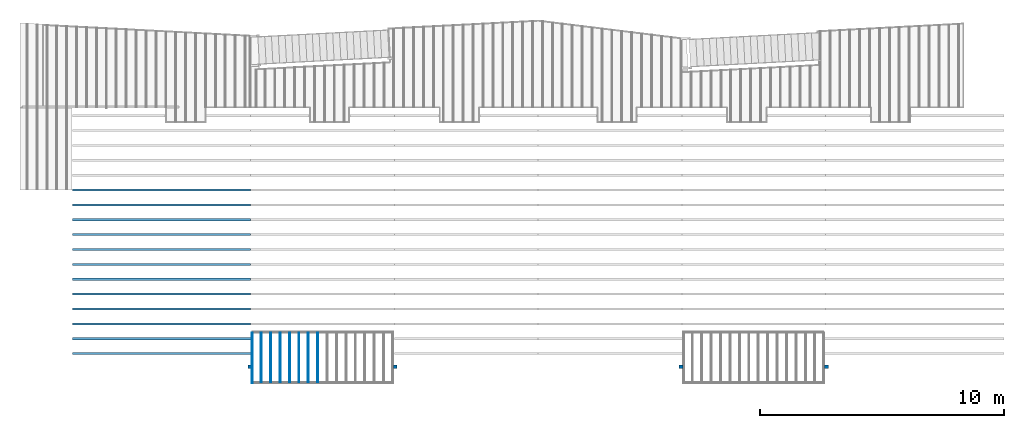
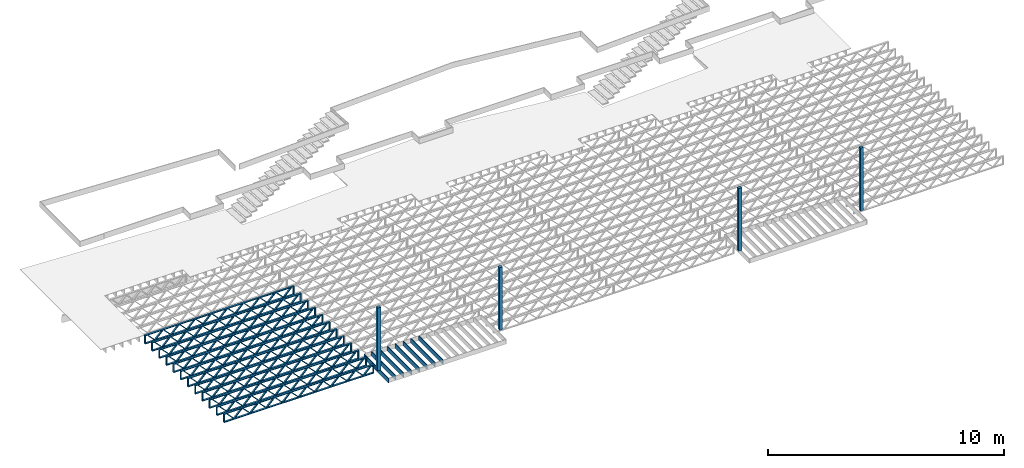
# One storey, part 1 of 23: 20 beams, 4 columns, 2 elements without a shape of their own.
"""IFC4 building model written with IfcOpenShell, lengths in feet."""

import ifcopenshell
import ifcopenshell.guid

model = None  # the IFC model being written
_history = None  # IfcOwnerHistory: only IFC2X3 demands one
_inside = {}  # id of a spatial element -> (the spatial element, [elements in it])
_under = {}  # id of a project, library or spatial element -> (it, [spatial elements below it])
_declared = {}  # id of a project -> (the project, [libraries it declares])
_typed = {}  # id of a type object -> (the type object, [elements of that type])
_made_of = {}  # id of a material, layer set ... -> (it, [elements and type objects made of it])


def new_model(schema):
    """Start an empty IFC model of exactly this schema.

    Asked for "IFC4X3", IfcOpenShell would pick the latest addendum, in which some entities
    have other attributes; the version numbers below select the first issue.
    IFC2X3 requires an IfcOwnerHistory on every rooted entity: one is made here for all.
    """
    global model, _history
    if schema == "IFC4X3":
        model = ifcopenshell.file(schema_version=(4, 3, 0, 0))
    else:
        model = ifcopenshell.file(schema=schema)
    _inside.clear()
    _under.clear()
    _declared.clear()
    _typed.clear()
    _made_of.clear()
    _history = None
    if model.schema == "IFC2X3":
        org = make("IfcOrganization", Name="unknown")
        user = make(
            "IfcPersonAndOrganization",
            ThePerson=make("IfcPerson", FamilyName="unknown"),
            TheOrganization=org,
        )
        app = make(
            "IfcApplication",
            ApplicationDeveloper=org,
            Version="unknown",
            ApplicationFullName="unknown",
            ApplicationIdentifier="unknown",
        )
        _history = make(
            "IfcOwnerHistory",
            OwningUser=user,
            OwningApplication=app,
            ChangeAction="ADDED",
            CreationDate=0,
        )
    return model


def make(cls, **values):
    """One entity of the class cls with the attributes given. An attribute that is None is left unset."""
    return model.create_entity(
        cls, **{name: value for name, value in values.items() if value is not None}
    )


def entity(cls, *values):
    """Any entity or typed value of the class cls, its attributes in the order of the schema. None: left unset."""
    e = model.create_entity(cls)
    for i, value in enumerate(values):
        if value is not None:
            e[i] = value
    return e


def rooted(cls, **values):
    """An entity with a GlobalId (a new one), such as an element, a storey or a relation."""
    return make(cls, GlobalId=ifcopenshell.guid.new(), OwnerHistory=_history, **values)


def si_unit(unit_type, name, prefix=None):
    """IfcSIUnit, for example si_unit("LENGTHUNIT", "METRE", prefix="MILLI")."""
    return make("IfcSIUnit", UnitType=unit_type, Prefix=prefix, Name=name)


def converted_unit(unit_type, name, factor, base, dimensions=None, offset=None):
    """IfcConversionBasedUnit, such as the inch: factor (a typed value) times the base unit."""
    return make(
        "IfcConversionBasedUnit"
        if offset is None
        else "IfcConversionBasedUnitWithOffset",
        ConversionOffset=offset,
        Dimensions=None
        if dimensions is None
        else entity("IfcDimensionalExponents", *dimensions),
        UnitType=unit_type,
        Name=name,
        ConversionFactor=make(
            "IfcMeasureWithUnit", ValueComponent=factor, UnitComponent=base
        ),
    )


def derived_unit(unit_type, elements):
    """IfcDerivedUnit: a product of units, each with its exponent."""
    return make(
        "IfcDerivedUnit",
        Elements=[
            make("IfcDerivedUnitElement", Unit=unit, Exponent=power)
            for unit, power in elements
        ],
        UnitType=unit_type,
    )


def assignment(units):
    """IfcUnitAssignment: the units of a project."""
    return None if units is None else make("IfcUnitAssignment", Units=units)


def point(xyz):
    """IfcCartesianPoint."""
    return None if xyz is None else make("IfcCartesianPoint", Coordinates=xyz)


def direction(xyz):
    """IfcDirection."""
    return None if xyz is None else make("IfcDirection", DirectionRatios=xyz)


def frame(location, z_axis=None, x_axis=None):
    """IfcAxis2Placement3D, a coordinate frame: its origin and axes. An axis left out is left unset."""
    return make(
        "IfcAxis2Placement3D",
        Location=point(location),
        Axis=direction(z_axis),
        RefDirection=direction(x_axis),
    )


def frame_2d(location, x_axis=None):
    """IfcAxis2Placement2D, a coordinate frame in the plane: its origin and x axis."""
    return make(
        "IfcAxis2Placement2D", Location=point(location), RefDirection=direction(x_axis)
    )


def origin():
    """The frame at (0, 0, 0) with its axes left unset."""
    return frame((0.0, 0.0, 0.0))


def origin_2d_with_axis():
    """The frame at (0, 0) in the plane with the x axis (1, 0) written out."""
    return frame_2d((0.0, 0.0), x_axis=(1.0, 0.0))


def place(relative_to, where):
    """IfcLocalPlacement: puts the frame where relative to a parent placement (None: the world)."""
    return make(
        "IfcLocalPlacement", PlacementRelTo=relative_to, RelativePlacement=where
    )


def context(
    kind, dimensions, precision=None, world=None, true_north=None, identifier=None
):
    """IfcGeometricRepresentationContext, for example the 3D "Model" context."""
    return make(
        "IfcGeometricRepresentationContext",
        ContextIdentifier=identifier,
        ContextType=kind,
        CoordinateSpaceDimension=dimensions,
        Precision=precision,
        WorldCoordinateSystem=world,
        TrueNorth=true_north,
    )


def subcontext(parent, identifier, kind, view, scale=None):
    """IfcGeometricRepresentationSubContext, for example "Body" below "Model"."""
    return make(
        "IfcGeometricRepresentationSubContext",
        ContextIdentifier=identifier,
        ContextType=kind,
        ParentContext=parent,
        TargetScale=scale,
        TargetView=view,
    )


def project(units=None, contexts=None):
    """IfcProject with its units and contexts."""
    return rooted(
        "IfcProject",
        Name="project",
        RepresentationContexts=contexts,
        UnitsInContext=assignment(units),
    )


def spatial(cls, under=None, at=None, **own):
    """A site, building, storey or space (cls), placed at a placement, below another one or the project."""
    s = rooted(cls, ObjectPlacement=at, **own)
    if under is not None:
        _under.setdefault(under.id(), (under, []))[1].append(s)
    return s


def profile(cls, at=None, kind="AREA", **sizes):
    """A parametric profile (cls). Its sizes go by their IFC names, for example OverallWidth=200.0."""
    return make(cls, ProfileType=kind, Position=at, **sizes)


def rectangle(**sizes):
    """IfcRectangleProfileDef."""
    return profile("IfcRectangleProfileDef", **sizes)


def extrude(swept, where, along, depth):
    """IfcExtrudedAreaSolid: the profile swept, set in the frame where, extruded along a direction by depth."""
    return make(
        "IfcExtrudedAreaSolid",
        SweptArea=swept,
        Position=where,
        ExtrudedDirection=direction(along),
        Depth=depth,
    )


def shape(context_of_items, identifier, shape_type, items):
    """IfcShapeRepresentation: the items that make up one representation, for example the "Body"."""
    return make(
        "IfcShapeRepresentation",
        ContextOfItems=context_of_items,
        RepresentationIdentifier=identifier,
        RepresentationType=shape_type,
        Items=items,
    )


def source(mapping_origin, context_of_items, identifier, shape_type, items):
    """IfcRepresentationMap: a shape defined once, which mapped items show again and again."""
    return make(
        "IfcRepresentationMap",
        MappingOrigin=mapping_origin,
        MappedRepresentation=shape(context_of_items, identifier, shape_type, items),
    )


def transform(
    local_origin,
    x_axis=None,
    y_axis=None,
    z_axis=None,
    scale=None,
    scale2=None,
    scale3=None,
    uniform=True,
):
    """IfcCartesianTransformationOperator3D, or its non-uniform kind. x_axis, y_axis, z_axis: its Axis1, 2, 3."""
    if uniform:
        return make(
            "IfcCartesianTransformationOperator3D",
            Axis1=direction(x_axis),
            Axis2=direction(y_axis),
            LocalOrigin=point(local_origin),
            Scale=scale,
            Axis3=direction(z_axis),
        )
    return make(
        "IfcCartesianTransformationOperator3DnonUniform",
        Axis1=direction(x_axis),
        Axis2=direction(y_axis),
        LocalOrigin=point(local_origin),
        Scale=scale,
        Axis3=direction(z_axis),
        Scale2=scale2,
        Scale3=scale3,
    )


def mapped(mapping_source, mapping_target):
    """IfcMappedItem: shows the shape of a source again, moved by a transform."""
    return make(
        "IfcMappedItem", MappingSource=mapping_source, MappingTarget=mapping_target
    )


def material(Name=None, Category=None):
    """IfcMaterial."""
    return make("IfcMaterial", Name=Name, Category=Category)


def material_profile(
    of_material, cross_section, Name=None, Category=None, Priority=None
):
    """IfcMaterialProfile: a cross section and its material."""
    return make(
        "IfcMaterialProfile",
        Name=Name,
        Material=of_material,
        Profile=cross_section,
        Priority=Priority,
        Category=Category,
    )


def profile_set(profiles, Name=None, composite=None):
    """IfcMaterialProfileSet."""
    return make(
        "IfcMaterialProfileSet",
        Name=Name,
        MaterialProfiles=profiles,
        CompositeProfile=composite,
    )


def profile_usage(for_profile_set, cardinal=None, extent=None):
    """IfcMaterialProfileSetUsage: how a profile set lies along its element."""
    return make(
        "IfcMaterialProfileSetUsage",
        ForProfileSet=for_profile_set,
        CardinalPoint=cardinal,
        ReferenceExtent=extent,
    )


def made_of(thing, what):
    """Note that an element or type object is made of a material, layer set ...; save() writes the relation."""
    if what is not None:
        _made_of.setdefault(what.id(), (what, []))[1].append(thing)
    return thing


def type_object(cls, material=None, **own):
    """A type object (cls), such as IfcWallType, which elements share."""
    return made_of(rooted(cls, **own), material)


def type_shapes(of_type, sources):
    """Give a type object the sources (RepresentationMaps) that its elements show as mapped items."""
    of_type.RepresentationMaps = sources


def element(
    cls,
    number,
    at=None,
    inside=None,
    cuts=None,
    type_object=None,
    material=None,
    context=None,
    identifier="Body",
    shape_type=None,
    held_by="IfcProductDefinitionShape",
    body=None,
    shapes=None,
    **own,
):
    """One element of the class cls, such as IfcWall. Its Tag is "e" and its number.

    at: its placement. inside: the storey or other place that contains it. cuts: it is an
    opening in that element (IfcRelVoidsElement). A single representation is given by context,
    identifier, shape_type and body (its items); several are given by shapes. held_by: the class
    of the entity that holds the representations. save() writes the other relations.
    """
    e = rooted(cls, Tag="e%d" % number, ObjectPlacement=at, **own)
    if body is not None:
        shapes = [shape(context, identifier, shape_type, body)]
    if shapes is not None:
        e.Representation = make(held_by, Representations=shapes)
    if inside is not None:
        _inside.setdefault(inside.id(), (inside, []))[1].append(e)
    if cuts is not None:
        rooted(
            "IfcRelVoidsElement", RelatingBuildingElement=cuts, RelatedOpeningElement=e
        )
    if type_object is not None:
        _typed.setdefault(type_object.id(), (type_object, []))[1].append(e)
    return made_of(e, material)


def aggregate(whole, parts):
    """IfcRelAggregates: a whole, such as a stair, and the parts it consists of."""
    return rooted("IfcRelAggregates", RelatingObject=whole, RelatedObjects=parts)


def save(model, path):
    """Write the relations noted so far, then the file.

    IfcRelAggregates (storeys below a building ...), IfcRelContainedInSpatialStructure (elements
    in a storey), IfcRelDefinesByType, IfcRelAssociatesMaterial and IfcRelDeclares: one each for
    every whole, place, type object, material and project.
    """
    for whole, parts in _under.values():
        aggregate(whole, parts)
    for where, things in _inside.values():
        rooted(
            "IfcRelContainedInSpatialStructure",
            RelatedElements=things,
            RelatingStructure=where,
        )
    for kind, things in _typed.values():
        rooted("IfcRelDefinesByType", RelatedObjects=things, RelatingType=kind)
    for what, things in _made_of.values():
        rooted("IfcRelAssociatesMaterial", RelatedObjects=things, RelatingMaterial=what)
    for by, libraries in _declared.values():
        rooted("IfcRelDeclares", RelatingContext=by, RelatedDefinitions=libraries)
    model.write(path)


model = new_model("IFC4")

# Units and contexts
model_context = context("Model", 3, precision=0.0001, world=origin(), true_north=direction((6.12303176911189e-17, 1.0)))
body_context = subcontext(model_context, "Body", "Model", "MODEL_VIEW")
ifc_project = project(units=[converted_unit("LENGTHUNIT", "FOOT", entity("IfcRatioMeasure", 0.3048), si_unit("LENGTHUNIT", "METRE"), dimensions=[1, 0, 0, 0, 0, 0, 0]), converted_unit("AREAUNIT", "SQUARE FOOT", entity("IfcRatioMeasure", 0.09290304), si_unit("AREAUNIT", "SQUARE_METRE"), dimensions=[2, 0, 0, 0, 0, 0, 0]), converted_unit("VOLUMEUNIT", "CUBIC FOOT", entity("IfcRatioMeasure", 0.028316846592), si_unit("VOLUMEUNIT", "CUBIC_METRE"), dimensions=[3, 0, 0, 0, 0, 0, 0]), converted_unit("PLANEANGLEUNIT", "DEGREE", entity("IfcRatioMeasure", 0.0174532925199433), si_unit("PLANEANGLEUNIT", "RADIAN"), dimensions=[0, 0, 0, 0, 0, 0, 0]), si_unit("MASSUNIT", "GRAM", prefix="KILO"), derived_unit("MASSDENSITYUNIT", [(si_unit("MASSUNIT", "GRAM", prefix="KILO"), 1), (si_unit("LENGTHUNIT", "METRE"), -3)]), derived_unit("MOMENTOFINERTIAUNIT", [(si_unit("LENGTHUNIT", "METRE"), 4)]), si_unit("TIMEUNIT", "SECOND"), si_unit("FREQUENCYUNIT", "HERTZ"), si_unit("THERMODYNAMICTEMPERATUREUNIT", "DEGREE_CELSIUS"), derived_unit("THERMALTRANSMITTANCEUNIT", [(si_unit("MASSUNIT", "GRAM", prefix="KILO"), 1), (si_unit("THERMODYNAMICTEMPERATUREUNIT", "KELVIN"), -1), (si_unit("TIMEUNIT", "SECOND"), -3)]), derived_unit("VOLUMETRICFLOWRATEUNIT", [(si_unit("LENGTHUNIT", "METRE"), 3), (si_unit("TIMEUNIT", "SECOND"), -1)]), si_unit("ELECTRICCURRENTUNIT", "AMPERE"), si_unit("ELECTRICVOLTAGEUNIT", "VOLT"), si_unit("POWERUNIT", "WATT"), si_unit("FORCEUNIT", "NEWTON"), si_unit("ILLUMINANCEUNIT", "LUX"), si_unit("LUMINOUSFLUXUNIT", "LUMEN"), si_unit("LUMINOUSINTENSITYUNIT", "CANDELA"), derived_unit("USERDEFINED", [(si_unit("MASSUNIT", "GRAM", prefix="KILO"), -1), (si_unit("LENGTHUNIT", "METRE"), -2), (si_unit("TIMEUNIT", "SECOND"), 3), (si_unit("LUMINOUSFLUXUNIT", "LUMEN"), 1)]), derived_unit("LINEARVELOCITYUNIT", [(si_unit("LENGTHUNIT", "METRE"), 1), (si_unit("TIMEUNIT", "SECOND"), -1)]), si_unit("PRESSUREUNIT", "PASCAL"), derived_unit("USERDEFINED", [(si_unit("LENGTHUNIT", "METRE"), -2), (si_unit("MASSUNIT", "GRAM", prefix="KILO"), 1), (si_unit("TIMEUNIT", "SECOND"), -2)]), derived_unit("LINEARFORCEUNIT", [(si_unit("MASSUNIT", "GRAM", prefix="KILO"), 1), (si_unit("LENGTHUNIT", "METRE"), 1), (si_unit("TIMEUNIT", "SECOND"), -2), (si_unit("LENGTHUNIT", "METRE"), -1)]), derived_unit("PLANARFORCEUNIT", [(si_unit("MASSUNIT", "GRAM", prefix="KILO"), 1), (si_unit("LENGTHUNIT", "METRE"), 1), (si_unit("TIMEUNIT", "SECOND"), -2), (si_unit("LENGTHUNIT", "METRE"), -2)])], contexts=[model_context])

# Site, building, storey
site_placement = place(None, origin())
site = spatial("IfcSite", under=ifc_project, at=site_placement, CompositionType="ELEMENT")
building_placement = place(site_placement, origin())
building = spatial("IfcBuilding", under=site, at=building_placement, CompositionType="ELEMENT")
storey_placement = place(building_placement, frame((0.0, 0.0, 10.8020833333333)))
storey = spatial("IfcBuildingStorey", under=building, at=storey_placement, Name="2ND FLOOR", CompositionType="ELEMENT", Elevation=10.8020833333333)

# Columns
ifc_material_1 = material(Name="STRUCTURAL WOOD COLUMN - SIZE TBD", Category="Materials")
ifc_material_profile_1 = material_profile(ifc_material_1, rectangle(XDim=0.458333333333333, YDim=0.5, at=frame_2d((0.0, -2.77555756156289e-17), x_axis=(1.0, 0.0))), Name="(4) 2X6 - BUILT-UP COLUMN")
ifc_profile_set_1 = profile_set([ifc_material_profile_1], Name="(4) 2X6 - BUILT-UP COLUMN")
ifc_profile_usage_1 = profile_usage(ifc_profile_set_1)
column_type = type_object("IfcColumnType", Name="Timber-Column:(4) 2X6 - BUILT-UP COLUMN", PredefinedType="COLUMN", material=ifc_profile_set_1)
shared_shape_1 = source(origin(), body_context, "Body", "SweptSolid", [
    extrude(rectangle(XDim=0.458333333333333, YDim=0.5, at=frame_2d((0.0, -2.77555756156289e-17), x_axis=(1.0, 0.0))), frame((0.0, 0.0, 10.8020833333333), z_axis=(0.0, 0.0, 1.0), x_axis=(0.0, -1.0, 0.0)), (0.0, 0.0, 1.0), 10.6666666666667),
])
type_shapes(column_type, [shared_shape_1])
column_1_placement = place(storey_placement, frame((-241.863160485529, 924.091101549317, -10.8020833333333)))
element("IfcColumn", 1, at=column_1_placement, inside=storey, type_object=column_type, material=ifc_profile_usage_1, Name="Timber-Column:(4) 2X6 - BUILT-UP COLUMN", ObjectType="Timber-Column:(4) 2X6 - BUILT-UP COLUMN", PredefinedType="COLUMN", context=body_context, shape_type="MappedRepresentation", body=[
    mapped(shared_shape_1, transform((0.0, 0.0, 0.0), scale=1.0)),
])
ifc_profile_usage_2 = profile_usage(ifc_profile_set_1)
column_2_placement = place(storey_placement, frame((-222.279828726425, 924.091101549317, -10.8020833333333)))
element("IfcColumn", 2, at=column_2_placement, inside=storey, type_object=column_type, material=ifc_profile_usage_2, Name="Timber-Column:(4) 2X6 - BUILT-UP COLUMN", ObjectType="Timber-Column:(4) 2X6 - BUILT-UP COLUMN", PredefinedType="COLUMN", context=body_context, shape_type="MappedRepresentation", body=[
    mapped(shared_shape_1, transform((0.0, 0.0, 0.0), scale=1.0)),
])
ifc_profile_usage_3 = profile_usage(ifc_profile_set_1)
column_3_placement = place(storey_placement, frame((-183.863160485529, 924.091101549317, -10.8020833333333)))
element("IfcColumn", 3, at=column_3_placement, inside=storey, type_object=column_type, material=ifc_profile_usage_3, Name="Timber-Column:(4) 2X6 - BUILT-UP COLUMN", ObjectType="Timber-Column:(4) 2X6 - BUILT-UP COLUMN", PredefinedType="COLUMN", context=body_context, shape_type="MappedRepresentation", body=[
    mapped(shared_shape_1, transform((0.0, 0.0, 0.0), scale=1.0)),
])
ifc_profile_usage_4 = profile_usage(ifc_profile_set_1)
column_4_placement = place(storey_placement, frame((-164.279827152195, 924.091101549317, -10.8020833333333)))
element("IfcColumn", 4, at=column_4_placement, inside=storey, type_object=column_type, material=ifc_profile_usage_4, Name="Timber-Column:(4) 2X6 - BUILT-UP COLUMN", ObjectType="Timber-Column:(4) 2X6 - BUILT-UP COLUMN", PredefinedType="COLUMN", context=body_context, shape_type="MappedRepresentation", body=[
    mapped(shared_shape_1, transform((0.0, 0.0, 0.0), scale=1.0)),
])

# Assembly, beams
assembly_1_placement = place(storey_placement, origin())
assembly_1 = element("IfcElementAssembly", 5, at=assembly_1_placement, inside=storey, Name="Structural Beam System:Structural Framing System", ObjectType="Structural Beam System:Structural Framing System", AssemblyPlace="NOTDEFINED", PredefinedType="BEAM_GRID")
ifc_material_2 = material(Category="Materials")
ifc_material_profile_2 = material_profile(ifc_material_2, rectangle(XDim=0.770833333333333, YDim=0.124999999999994, at=frame_2d((-5.55111512312578e-17, 0.0), x_axis=(1.0, 0.0))))
ifc_profile_set_2 = profile_set([ifc_material_profile_2])
ifc_profile_usage_5 = profile_usage(ifc_profile_set_2, cardinal=8)
beam_type_1 = type_object("IfcBeamType", PredefinedType="BEAM", material=ifc_profile_set_2)
shared_shape_2 = source(origin(), body_context, "Body", "SweptSolid", [
    extrude(rectangle(XDim=0.770833333333333, YDim=0.124999999999994, at=frame_2d((-5.55111512312578e-17, 0.0), x_axis=(1.0, 0.0))), frame((-3.35416666666737, 0.0, 0.0), z_axis=(1.0, 0.0, 0.0), x_axis=(0.0, 0.0, -1.0)), (0.0, 0.0, 1.0), 6.70833333333462),
])
type_shapes(beam_type_1, [shared_shape_2])
beam_1_placement = place(assembly_1_placement, frame((-240.307864615095, 925.341101549316, -0.645833333333471), z_axis=(0.0, 0.0, 1.0), x_axis=(0.0, 1.0, 0.0)))
beam_1 = element("IfcBeam", 6, at=beam_1_placement, type_object=beam_type_1, material=ifc_profile_usage_5, PredefinedType="BEAM", context=body_context, shape_type="MappedRepresentation", body=[
    mapped(shared_shape_2, transform((0.0, 0.0, 0.0), scale=1.0)),
])
ifc_profile_usage_6 = profile_usage(ifc_profile_set_2, cardinal=8)
beam_2_placement = place(assembly_1_placement, frame((-239.040980934537, 925.341101549316, -0.645833333333471), z_axis=(0.0, 0.0, 1.0), x_axis=(0.0, 1.0, 0.0)))
beam_2 = element("IfcBeam", 7, at=beam_2_placement, type_object=beam_type_1, material=ifc_profile_usage_6, PredefinedType="BEAM", context=body_context, shape_type="MappedRepresentation", body=[
    mapped(shared_shape_2, transform((0.0, 0.0, 0.0), scale=1.0)),
])
ifc_profile_usage_7 = profile_usage(ifc_profile_set_2, cardinal=8)
beam_3_placement = place(assembly_1_placement, frame((-237.774097253978, 925.341101549316, -0.645833333333471), z_axis=(0.0, 0.0, 1.0), x_axis=(0.0, 1.0, 0.0)))
beam_3 = element("IfcBeam", 8, at=beam_3_placement, type_object=beam_type_1, material=ifc_profile_usage_7, PredefinedType="BEAM", context=body_context, shape_type="MappedRepresentation", body=[
    mapped(shared_shape_2, transform((0.0, 0.0, 0.0), scale=1.0)),
])
ifc_profile_usage_8 = profile_usage(ifc_profile_set_2, cardinal=8)
beam_4_placement = place(assembly_1_placement, frame((-236.50721357342, 925.341101549317, -0.645833333333471), z_axis=(0.0, 0.0, 1.0), x_axis=(0.0, 1.0, 0.0)))
beam_4 = element("IfcBeam", 9, at=beam_4_placement, type_object=beam_type_1, material=ifc_profile_usage_8, PredefinedType="BEAM", context=body_context, shape_type="MappedRepresentation", body=[
    mapped(shared_shape_2, transform((0.0, 0.0, 0.0), scale=1.0)),
])
ifc_profile_usage_9 = profile_usage(ifc_profile_set_2, cardinal=8)
beam_5_placement = place(assembly_1_placement, frame((-235.240329892862, 925.341101549317, -0.645833333333471), z_axis=(0.0, 0.0, 1.0), x_axis=(0.0, 1.0, 0.0)))
beam_5 = element("IfcBeam", 10, at=beam_5_placement, type_object=beam_type_1, material=ifc_profile_usage_9, PredefinedType="BEAM", context=body_context, shape_type="MappedRepresentation", body=[
    mapped(shared_shape_2, transform((0.0, 0.0, 0.0), scale=1.0)),
])
ifc_profile_usage_10 = profile_usage(ifc_profile_set_2, cardinal=8)
beam_6_placement = place(assembly_1_placement, frame((-233.973446212303, 925.341101549317, -0.645833333333471), z_axis=(0.0, 0.0, 1.0), x_axis=(0.0, 1.0, 0.0)))
beam_6 = element("IfcBeam", 11, at=beam_6_placement, type_object=beam_type_1, material=ifc_profile_usage_10, PredefinedType="BEAM", context=body_context, shape_type="MappedRepresentation", body=[
    mapped(shared_shape_2, transform((0.0, 0.0, 0.0), scale=1.0)),
])
ifc_profile_usage_11 = profile_usage(ifc_profile_set_2, cardinal=8)
beam_7_placement = place(assembly_1_placement, frame((-232.706562531745, 925.341101549317, -0.645833333333471), z_axis=(0.0, 0.0, 1.0), x_axis=(0.0, 1.0, 0.0)))
beam_7 = element("IfcBeam", 12, at=beam_7_placement, type_object=beam_type_1, material=ifc_profile_usage_11, PredefinedType="BEAM", context=body_context, shape_type="MappedRepresentation", body=[
    mapped(shared_shape_2, transform((0.0, 0.0, 0.0), scale=1.0)),
])
aggregate(assembly_1, [beam_1, beam_2, beam_3, beam_4, beam_5, beam_6, beam_7])

assembly_2_placement = place(storey_placement, origin())
assembly_2 = element("IfcElementAssembly", 13, at=assembly_2_placement, inside=storey, Name="Structural Beam System:Structural Framing System", ObjectType="Structural Beam System:Structural Framing System", AssemblyPlace="NOTDEFINED", PredefinedType="BEAM_GRID")
ifc_material_3 = material(Name="WOOD TRUSS", Category="Materials")
ifc_material_profile_3 = material_profile(ifc_material_3, rectangle(XDim=1.73473973950632, YDim=0.125, at=frame_2d((-1.11022302462516e-16, 8.32667268468867e-17), x_axis=(1.0, 0.0))))
ifc_material_profile_4 = material_profile(ifc_material_3, rectangle(XDim=1.73473973950633, YDim=0.125, at=frame_2d((-1.11022302462516e-16, 8.32667268468867e-17), x_axis=(1.0, 0.0))))
ifc_material_profile_5 = material_profile(ifc_material_3, rectangle(XDim=1.73473973950632, YDim=0.125, at=frame_2d((-5.55111512312578e-17, 1.38777878078145e-16), x_axis=(1.0, 0.0))))
ifc_material_profile_6 = material_profile(ifc_material_3, rectangle(XDim=1.73473973950633, YDim=0.125, at=frame_2d((-1.11022302462516e-16, 8.32667268468867e-17), x_axis=(1.0, 0.0))))
ifc_material_profile_7 = material_profile(ifc_material_3, rectangle(XDim=1.73473973950632, YDim=0.125, at=frame_2d((-1.11022302462516e-16, 8.32667268468867e-17), x_axis=(1.0, 0.0))))
ifc_material_profile_8 = material_profile(ifc_material_3, rectangle(XDim=1.73473973950633, YDim=0.125, at=frame_2d((-2.77555756156289e-16, 3.05311331771918e-16), x_axis=(1.0, 0.0))))
ifc_material_profile_9 = material_profile(ifc_material_3, rectangle(XDim=1.73473973950632, YDim=0.124999999999999, at=frame_2d((-3.88578058618805e-16, -2.4980018054066e-16), x_axis=(1.0, 0.0))))
ifc_material_profile_10 = material_profile(ifc_material_3, rectangle(XDim=1.73473973950633, YDim=0.125, at=frame_2d((2.77555756156289e-16, -3.05311331771918e-16), x_axis=(1.0, 0.0))))
ifc_material_profile_11 = material_profile(ifc_material_3, rectangle(XDim=1.73473973950632, YDim=0.124999999999999, at=frame_2d((-1.11022302462516e-16, 8.32667268468867e-17), x_axis=(1.0, 0.0))))
ifc_material_profile_12 = material_profile(ifc_material_3, rectangle(XDim=1.73473973950633, YDim=0.125, at=origin_2d_with_axis()))
ifc_material_profile_13 = material_profile(ifc_material_3, rectangle(XDim=0.124999999999982, YDim=0.291666666666668, at=origin_2d_with_axis()))
ifc_material_profile_14 = material_profile(ifc_material_3, rectangle(XDim=0.124999999999932, YDim=0.291666666666664, at=origin_2d_with_axis()))
ifc_material_profile_15 = material_profile(ifc_material_3, rectangle(XDim=1.25000000000002, YDim=0.29166666666667, at=origin_2d_with_axis()))
ifc_material_profile_16 = material_profile(ifc_material_3, rectangle(XDim=1.25000000000004, YDim=0.291666666666667, at=origin_2d_with_axis()))
ifc_profile_set_3 = profile_set([ifc_material_profile_3, ifc_material_profile_4, ifc_material_profile_5, ifc_material_profile_6, ifc_material_profile_7, ifc_material_profile_8, ifc_material_profile_9, ifc_material_profile_10, ifc_material_profile_11, ifc_material_profile_12, ifc_material_profile_13, ifc_material_profile_14, ifc_material_profile_15, ifc_material_profile_16])
ifc_profile_usage_12 = profile_usage(ifc_profile_set_3, cardinal=8)
beam_type_2 = type_object("IfcBeamType", PredefinedType="BEAM", material=ifc_profile_set_3)
shared_shape_3 = source(origin(), body_context, "Body", "SweptSolid", [
    extrude(rectangle(XDim=1.73473973950632, YDim=0.124999999999999, at=frame_2d((5.55111512312578e-16, 7.21644966006352e-16), x_axis=(1.0, 0.0))), frame((8.37514585578398, -0.145833333333334, 0.0), z_axis=(0.0, 1.0, 0.0), x_axis=(0.693383046997606, 0.0, 0.720569184836762)), (0.0, 0.0, 1.0), 0.291666666666667),
    extrude(rectangle(XDim=1.73473973950633, YDim=0.125, at=origin_2d_with_axis()), frame((7.12485998211071, -0.145833333333334, 0.0), z_axis=(0.0, 1.0, 0.0), x_axis=(0.69338304699761, 0.0, -0.720569184836758)), (0.0, 0.0, 1.0), 0.291666666666666),
    extrude(rectangle(XDim=1.73473973950632, YDim=0.124999999999999, at=frame_2d((-1.11022302462516e-16, 8.32667268468867e-17), x_axis=(1.0, 0.0))), frame((5.79181154946831, -0.145833333333334, 0.0), z_axis=(0.0, 1.0, 0.0), x_axis=(0.693383046997606, 0.0, 0.720569184836762)), (0.0, 0.0, 1.0), 0.291666666666667),
    extrude(rectangle(XDim=1.73473973950633, YDim=0.125, at=origin_2d_with_axis()), frame((4.54152567579504, -0.145833333333334, 0.0), z_axis=(0.0, 1.0, 0.0), x_axis=(0.69338304699761, 0.0, -0.720569184836758)), (0.0, 0.0, 1.0), 0.291666666666666),
    extrude(rectangle(XDim=1.73473973950632, YDim=0.125, at=frame_2d((2.22044604925031e-16, 3.88578058618805e-16), x_axis=(1.0, 0.0))), frame((3.20847724315264, -0.145833333333334, 0.0), z_axis=(0.0, 1.0, 0.0), x_axis=(0.693383046997606, 0.0, 0.720569184836762)), (0.0, 0.0, 1.0), 0.291666666666667),
    extrude(rectangle(XDim=1.73473973950633, YDim=0.125, at=frame_2d((-1.11022302462516e-16, 8.32667268468867e-17), x_axis=(1.0, 0.0))), frame((1.95819136947937, -0.145833333333334, 0.0), z_axis=(0.0, 1.0, 0.0), x_axis=(0.69338304699761, 0.0, -0.720569184836758)), (0.0, 0.0, 1.0), 0.291666666666667),
    extrude(rectangle(XDim=1.73473973950632, YDim=0.125, at=frame_2d((-5.55111512312578e-17, 1.38777878078145e-16), x_axis=(1.0, 0.0))), frame((0.625142936836964, -0.145833333333334, 0.0), z_axis=(0.0, 1.0, 0.0), x_axis=(0.693383046997606, 0.0, 0.720569184836762)), (0.0, 0.0, 1.0), 0.291666666666667),
    extrude(rectangle(XDim=1.73473973950633, YDim=0.125, at=frame_2d((-1.11022302462516e-16, 8.32667268468867e-17), x_axis=(1.0, 0.0))), frame((-0.625142936836306, -0.145833333333334, 0.0), z_axis=(0.0, 1.0, 0.0), x_axis=(0.69338304699761, 0.0, -0.720569184836758)), (0.0, 0.0, 1.0), 0.291666666666667),
    extrude(rectangle(XDim=1.73473973950632, YDim=0.125, at=frame_2d((-1.11022302462516e-16, 8.32667268468867e-17), x_axis=(1.0, 0.0))), frame((-1.95819136947871, -0.145833333333334, 0.0), z_axis=(0.0, 1.0, 0.0), x_axis=(0.693383046997606, 0.0, 0.720569184836762)), (0.0, 0.0, 1.0), 0.291666666666667),
    extrude(rectangle(XDim=1.73473973950633, YDim=0.125, at=origin_2d_with_axis()), frame((-3.20847724315198, -0.145833333333334, 0.0), z_axis=(0.0, 1.0, 0.0), x_axis=(0.69338304699761, 0.0, -0.720569184836758)), (0.0, 0.0, 1.0), 0.291666666666667),
    extrude(rectangle(XDim=1.73473973950632, YDim=0.124999999999999, at=frame_2d((-1.11022302462516e-16, 8.32667268468867e-17), x_axis=(1.0, 0.0))), frame((-4.54152567579438, -0.145833333333334, 0.0), z_axis=(0.0, 1.0, 0.0), x_axis=(0.693383046997606, 0.0, 0.720569184836762)), (0.0, 0.0, 1.0), 0.291666666666667),
    extrude(rectangle(XDim=1.73473973950633, YDim=0.125, at=origin_2d_with_axis()), frame((-5.79181154946765, -0.145833333333334, 0.0), z_axis=(0.0, 1.0, 0.0), x_axis=(0.69338304699761, 0.0, -0.720569184836758)), (0.0, 0.0, 1.0), 0.291666666666666),
    extrude(rectangle(XDim=1.73473973950632, YDim=0.124999999999999, at=frame_2d((-1.11022302462516e-16, 8.32667268468867e-17), x_axis=(1.0, 0.0))), frame((-7.12485998211005, -0.145833333333334, 0.0), z_axis=(0.0, 1.0, 0.0), x_axis=(0.693383046997606, 0.0, 0.720569184836762)), (0.0, 0.0, 1.0), 0.291666666666667),
    extrude(rectangle(XDim=1.73473973950633, YDim=0.125, at=frame_2d((-2.77555756156289e-16, 3.05311331771918e-16), x_axis=(1.0, 0.0))), frame((-8.37514585578332, -0.145833333333334, 0.0), z_axis=(0.0, 1.0, 0.0), x_axis=(0.69338304699761, 0.0, -0.720569184836758)), (0.0, 0.0, 1.0), 0.291666666666666),
    extrude(rectangle(XDim=1.73473973950632, YDim=0.125, at=frame_2d((-7.21644966006352e-16, -5.55111512312578e-16), x_axis=(1.0, 0.0))), frame((10.9584801620997, -0.145833333333334, 0.0), z_axis=(0.0, 1.0, 0.0), x_axis=(0.693383046997606, 0.0, 0.720569184836762)), (0.0, 0.0, 1.0), 0.291666666666667),
    extrude(rectangle(XDim=1.73473973950633, YDim=0.125, at=origin_2d_with_axis()), frame((9.70819428842638, -0.145833333333334, 0.0), z_axis=(0.0, 1.0, 0.0), x_axis=(0.69338304699761, 0.0, -0.720569184836758)), (0.0, 0.0, 1.0), 0.291666666666666),
    extrude(rectangle(XDim=1.73473973950632, YDim=0.125, at=frame_2d((-5.55111512312578e-17, 8.32667268468867e-17), x_axis=(1.0, 0.0))), frame((-9.70819428842572, -0.145833333333334, 0.0), z_axis=(0.0, 1.0, 0.0), x_axis=(0.693383046997606, 0.0, 0.720569184836762)), (0.0, 0.0, 1.0), 0.291666666666667),
    extrude(rectangle(XDim=1.73473973950633, YDim=0.125, at=origin_2d_with_axis()), frame((-10.958480162099, -0.145833333333334, 0.0), z_axis=(0.0, 1.0, 0.0), x_axis=(0.69338304699761, 0.0, -0.720569184836758)), (0.0, 0.0, 1.0), 0.291666666666666),
    extrude(rectangle(XDim=0.124999999999982, YDim=0.291666666666668, at=origin_2d_with_axis()), frame((-12.0000038919293, 0.0, 0.687500000000054), z_axis=(1.0, 0.0, 0.0), x_axis=(0.0, 0.0, -1.0)), (0.0, 0.0, 1.0), 24.0000077838585),
    extrude(rectangle(XDim=0.124999999999932, YDim=0.291666666666664, at=origin_2d_with_axis()), frame((-12.0000038919291, 0.0, -0.687499999999984), z_axis=(1.0, 0.0, 0.0), x_axis=(0.0, 0.0, -1.0)), (0.0, 0.0, 1.0), 24.0000077838583),
    extrude(rectangle(XDim=1.25000000000002, YDim=0.29166666666667, at=origin_2d_with_axis()), frame((11.8750038919292, 0.0, 0.0), z_axis=(1.0, 0.0, 0.0), x_axis=(0.0, 0.0, -1.0)), (0.0, 0.0, 1.0), 0.12500000000002),
    extrude(rectangle(XDim=1.25000000000004, YDim=0.291666666666667, at=origin_2d_with_axis()), frame((-12.0000038919293, 0.0, 0.0), z_axis=(1.0, 0.0, 0.0), x_axis=(0.0, 0.0, -1.0)), (0.0, 0.0, 1.0), 0.125000000000023),
])
type_shapes(beam_type_2, [shared_shape_3])
beam_8_placement = place(assembly_2_placement, frame((-253.738164405664, 947.861934882651, -0.947916666657859)))
beam_8 = element("IfcBeam", 14, at=beam_8_placement, type_object=beam_type_2, material=ifc_profile_usage_12, PredefinedType="BEAM", context=body_context, shape_type="MappedRepresentation", body=[
    mapped(shared_shape_3, transform((0.0, 0.0, 0.0), scale=1.0)),
])
ifc_profile_usage_13 = profile_usage(ifc_profile_set_3, cardinal=8)
beam_9_placement = place(assembly_2_placement, frame((-253.738164405664, 945.861934882651, -0.947916666657859)))
beam_9 = element("IfcBeam", 15, at=beam_9_placement, type_object=beam_type_2, material=ifc_profile_usage_13, PredefinedType="BEAM", context=body_context, shape_type="MappedRepresentation", body=[
    mapped(shared_shape_3, transform((0.0, 0.0, 0.0), scale=1.0)),
])
ifc_profile_usage_14 = profile_usage(ifc_profile_set_3, cardinal=8)
beam_10_placement = place(assembly_2_placement, frame((-253.738164405664, 943.861934882651, -0.947916666657859)))
beam_10 = element("IfcBeam", 16, at=beam_10_placement, type_object=beam_type_2, material=ifc_profile_usage_14, PredefinedType="BEAM", context=body_context, shape_type="MappedRepresentation", body=[
    mapped(shared_shape_3, transform((0.0, 0.0, 0.0), scale=1.0)),
])
ifc_profile_usage_15 = profile_usage(ifc_profile_set_3, cardinal=8)
beam_11_placement = place(assembly_2_placement, frame((-253.738164405664, 941.861934882651, -0.947916666657859)))
beam_11 = element("IfcBeam", 17, at=beam_11_placement, type_object=beam_type_2, material=ifc_profile_usage_15, PredefinedType="BEAM", context=body_context, shape_type="MappedRepresentation", body=[
    mapped(shared_shape_3, transform((0.0, 0.0, 0.0), scale=1.0)),
])
ifc_profile_usage_16 = profile_usage(ifc_profile_set_3, cardinal=8)
beam_12_placement = place(assembly_2_placement, frame((-253.738164405664, 939.861934882651, -0.947916666657859)))
beam_12 = element("IfcBeam", 18, at=beam_12_placement, type_object=beam_type_2, material=ifc_profile_usage_16, PredefinedType="BEAM", context=body_context, shape_type="MappedRepresentation", body=[
    mapped(shared_shape_3, transform((0.0, 0.0, 0.0), scale=1.0)),
])
ifc_profile_usage_17 = profile_usage(ifc_profile_set_3, cardinal=8)
beam_13_placement = place(assembly_2_placement, frame((-253.738164405664, 937.861934882651, -0.947916666657859)))
beam_13 = element("IfcBeam", 19, at=beam_13_placement, type_object=beam_type_2, material=ifc_profile_usage_17, PredefinedType="BEAM", context=body_context, shape_type="MappedRepresentation", body=[
    mapped(shared_shape_3, transform((0.0, 0.0, 0.0), scale=1.0)),
])
ifc_profile_usage_18 = profile_usage(ifc_profile_set_3, cardinal=8)
beam_14_placement = place(assembly_2_placement, frame((-253.738164405664, 935.861934882651, -0.947916666657859)))
beam_14 = element("IfcBeam", 20, at=beam_14_placement, type_object=beam_type_2, material=ifc_profile_usage_18, PredefinedType="BEAM", context=body_context, shape_type="MappedRepresentation", body=[
    mapped(shared_shape_3, transform((0.0, 0.0, 0.0), scale=1.0)),
])
ifc_profile_usage_19 = profile_usage(ifc_profile_set_3, cardinal=8)
beam_15_placement = place(assembly_2_placement, frame((-253.738164405664, 933.861934882651, -0.947916666657859)))
beam_15 = element("IfcBeam", 21, at=beam_15_placement, type_object=beam_type_2, material=ifc_profile_usage_19, PredefinedType="BEAM", context=body_context, shape_type="MappedRepresentation", body=[
    mapped(shared_shape_3, transform((0.0, 0.0, 0.0), scale=1.0)),
])
ifc_profile_usage_20 = profile_usage(ifc_profile_set_3, cardinal=8)
beam_16_placement = place(assembly_2_placement, frame((-253.738164405664, 931.861934882651, -0.947916666657859)))
beam_16 = element("IfcBeam", 22, at=beam_16_placement, type_object=beam_type_2, material=ifc_profile_usage_20, PredefinedType="BEAM", context=body_context, shape_type="MappedRepresentation", body=[
    mapped(shared_shape_3, transform((0.0, 0.0, 0.0), scale=1.0)),
])
ifc_profile_usage_21 = profile_usage(ifc_profile_set_3, cardinal=8)
beam_17_placement = place(assembly_2_placement, frame((-253.738164405664, 929.861934882651, -0.947916666657859)))
beam_17 = element("IfcBeam", 23, at=beam_17_placement, type_object=beam_type_2, material=ifc_profile_usage_21, PredefinedType="BEAM", context=body_context, shape_type="MappedRepresentation", body=[
    mapped(shared_shape_3, transform((0.0, 0.0, 0.0), scale=1.0)),
])
ifc_profile_usage_22 = profile_usage(ifc_profile_set_3, cardinal=8)
beam_type_3 = type_object("IfcBeamType", PredefinedType="BEAM", material=ifc_profile_set_3)
shared_shape_4 = source(origin(), body_context, "Body", "SweptSolid", [
    extrude(rectangle(XDim=1.73473973950632, YDim=0.124999999999999, at=frame_2d((5.55111512312578e-16, 7.21644966006352e-16), x_axis=(1.0, 0.0))), frame((8.42202085580899, -0.145833333333334, 0.0), z_axis=(0.0, 1.0, 0.0), x_axis=(0.693383046997606, 0.0, 0.720569184836762)), (0.0, 0.0, 1.0), 0.291666666666667),
    extrude(rectangle(XDim=1.73473973950633, YDim=0.125, at=origin_2d_with_axis()), frame((7.17173498213572, -0.145833333333334, 0.0), z_axis=(0.0, 1.0, 0.0), x_axis=(0.69338304699761, 0.0, -0.720569184836758)), (0.0, 0.0, 1.0), 0.291666666666666),
    extrude(rectangle(XDim=1.73473973950632, YDim=0.124999999999999, at=frame_2d((-1.11022302462516e-16, 8.32667268468867e-17), x_axis=(1.0, 0.0))), frame((5.82306154948498, -0.145833333333334, 0.0), z_axis=(0.0, 1.0, 0.0), x_axis=(0.693383046997606, 0.0, 0.720569184836762)), (0.0, 0.0, 1.0), 0.291666666666667),
    extrude(rectangle(XDim=1.73473973950633, YDim=0.125, at=origin_2d_with_axis()), frame((4.57277567581171, -0.145833333333334, 0.0), z_axis=(0.0, 1.0, 0.0), x_axis=(0.69338304699761, 0.0, -0.720569184836758)), (0.0, 0.0, 1.0), 0.291666666666666),
    extrude(rectangle(XDim=1.73473973950632, YDim=0.125, at=frame_2d((2.22044604925031e-16, 3.88578058618805e-16), x_axis=(1.0, 0.0))), frame((3.22410224316097, -0.145833333333334, 0.0), z_axis=(0.0, 1.0, 0.0), x_axis=(0.693383046997606, 0.0, 0.720569184836762)), (0.0, 0.0, 1.0), 0.291666666666667),
    extrude(rectangle(XDim=1.73473973950633, YDim=0.125, at=frame_2d((-1.11022302462516e-16, 8.32667268468867e-17), x_axis=(1.0, 0.0))), frame((1.9738163694877, -0.145833333333334, 0.0), z_axis=(0.0, 1.0, 0.0), x_axis=(0.69338304699761, 0.0, -0.720569184836758)), (0.0, 0.0, 1.0), 0.291666666666667),
    extrude(rectangle(XDim=1.73473973950632, YDim=0.125, at=frame_2d((-5.55111512312578e-17, 1.38777878078145e-16), x_axis=(1.0, 0.0))), frame((0.625142936836964, -0.145833333333334, 0.0), z_axis=(0.0, 1.0, 0.0), x_axis=(0.693383046997606, 0.0, 0.720569184836762)), (0.0, 0.0, 1.0), 0.291666666666667),
    extrude(rectangle(XDim=1.73473973950633, YDim=0.125, at=frame_2d((-1.11022302462516e-16, 8.32667268468867e-17), x_axis=(1.0, 0.0))), frame((-0.625142936836306, -0.145833333333334, 0.0), z_axis=(0.0, 1.0, 0.0), x_axis=(0.69338304699761, 0.0, -0.720569184836758)), (0.0, 0.0, 1.0), 0.291666666666667),
    extrude(rectangle(XDim=1.73473973950632, YDim=0.125, at=frame_2d((-1.11022302462516e-16, 8.32667268468867e-17), x_axis=(1.0, 0.0))), frame((-1.97381636948704, -0.145833333333334, 0.0), z_axis=(0.0, 1.0, 0.0), x_axis=(0.693383046997606, 0.0, 0.720569184836762)), (0.0, 0.0, 1.0), 0.291666666666667),
    extrude(rectangle(XDim=1.73473973950633, YDim=0.125, at=origin_2d_with_axis()), frame((-3.22410224316031, -0.145833333333334, 0.0), z_axis=(0.0, 1.0, 0.0), x_axis=(0.69338304699761, 0.0, -0.720569184836758)), (0.0, 0.0, 1.0), 0.291666666666667),
    extrude(rectangle(XDim=1.73473973950632, YDim=0.124999999999999, at=frame_2d((-1.11022302462516e-16, 8.32667268468867e-17), x_axis=(1.0, 0.0))), frame((-4.57277567581105, -0.145833333333334, 0.0), z_axis=(0.0, 1.0, 0.0), x_axis=(0.693383046997606, 0.0, 0.720569184836762)), (0.0, 0.0, 1.0), 0.291666666666667),
    extrude(rectangle(XDim=1.73473973950633, YDim=0.125, at=origin_2d_with_axis()), frame((-5.82306154948432, -0.145833333333334, 0.0), z_axis=(0.0, 1.0, 0.0), x_axis=(0.69338304699761, 0.0, -0.720569184836758)), (0.0, 0.0, 1.0), 0.291666666666666),
    extrude(rectangle(XDim=1.73473973950632, YDim=0.124999999999999, at=frame_2d((-1.11022302462516e-16, 8.32667268468867e-17), x_axis=(1.0, 0.0))), frame((-7.17173498213506, -0.145833333333334, 0.0), z_axis=(0.0, 1.0, 0.0), x_axis=(0.693383046997606, 0.0, 0.720569184836762)), (0.0, 0.0, 1.0), 0.291666666666667),
    extrude(rectangle(XDim=1.73473973950633, YDim=0.125, at=frame_2d((-2.77555756156289e-16, 3.05311331771918e-16), x_axis=(1.0, 0.0))), frame((-8.42202085580833, -0.145833333333334, 0.0), z_axis=(0.0, 1.0, 0.0), x_axis=(0.69338304699761, 0.0, -0.720569184836758)), (0.0, 0.0, 1.0), 0.291666666666666),
    extrude(rectangle(XDim=1.73473973950632, YDim=0.125, at=frame_2d((-7.21644966006352e-16, -5.55111512312578e-16), x_axis=(1.0, 0.0))), frame((11.020980162133, -0.145833333333334, 0.0), z_axis=(0.0, 1.0, 0.0), x_axis=(0.693383046997606, 0.0, 0.720569184836762)), (0.0, 0.0, 1.0), 0.291666666666667),
    extrude(rectangle(XDim=1.73473973950633, YDim=0.125, at=origin_2d_with_axis()), frame((9.77069428845972, -0.145833333333334, 0.0), z_axis=(0.0, 1.0, 0.0), x_axis=(0.69338304699761, 0.0, -0.720569184836758)), (0.0, 0.0, 1.0), 0.291666666666666),
    extrude(rectangle(XDim=1.73473973950632, YDim=0.125, at=frame_2d((-5.55111512312578e-17, 8.32667268468867e-17), x_axis=(1.0, 0.0))), frame((-9.77069428845906, -0.145833333333334, 0.0), z_axis=(0.0, 1.0, 0.0), x_axis=(0.693383046997606, 0.0, 0.720569184836762)), (0.0, 0.0, 1.0), 0.291666666666667),
    extrude(rectangle(XDim=1.73473973950633, YDim=0.125, at=origin_2d_with_axis()), frame((-11.0209801621323, -0.145833333333334, 0.0), z_axis=(0.0, 1.0, 0.0), x_axis=(0.69338304699761, 0.0, -0.720569184836758)), (0.0, 0.0, 1.0), 0.291666666666666),
    extrude(rectangle(XDim=0.124999999999982, YDim=0.291666666666668, at=origin_2d_with_axis()), frame((-12.0625038919626, 0.0, 0.687500000000054), z_axis=(1.0, 0.0, 0.0), x_axis=(0.0, 0.0, -1.0)), (0.0, 0.0, 1.0), 24.1250077839252),
    extrude(rectangle(XDim=0.124999999999932, YDim=0.291666666666664, at=origin_2d_with_axis()), frame((-12.0625038919624, 0.0, -0.687499999999984), z_axis=(1.0, 0.0, 0.0), x_axis=(0.0, 0.0, -1.0)), (0.0, 0.0, 1.0), 24.125007783925),
    extrude(rectangle(XDim=1.25000000000002, YDim=0.29166666666667, at=origin_2d_with_axis()), frame((11.9375038919626, 0.0, 0.0), z_axis=(1.0, 0.0, 0.0), x_axis=(0.0, 0.0, -1.0)), (0.0, 0.0, 1.0), 0.12500000000002),
    extrude(rectangle(XDim=1.25000000000004, YDim=0.291666666666667, at=origin_2d_with_axis()), frame((-12.0625038919626, 0.0, 0.0), z_axis=(1.0, 0.0, 0.0), x_axis=(0.0, 0.0, -1.0)), (0.0, 0.0, 1.0), 0.125000000000023),
])
type_shapes(beam_type_3, [shared_shape_4])
beam_18_placement = place(assembly_2_placement, frame((-253.675664405631, 927.861934882651, -0.947916666657859)))
beam_18 = element("IfcBeam", 24, at=beam_18_placement, type_object=beam_type_3, material=ifc_profile_usage_22, PredefinedType="BEAM", context=body_context, shape_type="MappedRepresentation", body=[
    mapped(shared_shape_4, transform((0.0, 0.0, 0.0), scale=1.0)),
])
ifc_profile_usage_23 = profile_usage(ifc_profile_set_3, cardinal=8)
beam_19_placement = place(assembly_2_placement, frame((-253.675664405631, 925.861934882651, -0.947916666657859)))
beam_19 = element("IfcBeam", 25, at=beam_19_placement, type_object=beam_type_3, material=ifc_profile_usage_23, PredefinedType="BEAM", context=body_context, shape_type="MappedRepresentation", body=[
    mapped(shared_shape_4, transform((0.0, 0.0, 0.0), scale=1.0)),
])
aggregate(assembly_2, [beam_8, beam_9, beam_10, beam_11, beam_12, beam_13, beam_14, beam_15, beam_16, beam_17, beam_18, beam_19])

# Beam
ifc_profile_usage_24 = profile_usage(ifc_profile_set_2, cardinal=8)
beam_type_4 = type_object("IfcBeamType", PredefinedType="BEAM", material=ifc_profile_set_2)
shared_shape_5 = source(origin(), body_context, "Body", "SweptSolid", [
    extrude(rectangle(XDim=0.770833333333333, YDim=0.124999999999994, at=origin_2d_with_axis()), frame((-3.47916666666737, 0.0, 0.0), z_axis=(1.0, 0.0, 0.0), x_axis=(0.0, 0.0, -1.0)), (0.0, 0.0, 1.0), 6.83333333333471),
])
type_shapes(beam_type_4, [shared_shape_5])
beam_20_placement = place(storey_placement, frame((-241.508993818863, 925.341101549316, -0.645833333332796), z_axis=(0.0, 0.0, 1.0), x_axis=(0.0, 1.0, 0.0)))
element("IfcBeam", 26, at=beam_20_placement, inside=storey, type_object=beam_type_4, material=ifc_profile_usage_24, PredefinedType="BEAM", context=body_context, shape_type="MappedRepresentation", body=[
    mapped(shared_shape_5, transform((0.0, 0.0, 0.0), scale=1.0)),
])

save(model, "model.ifc")
